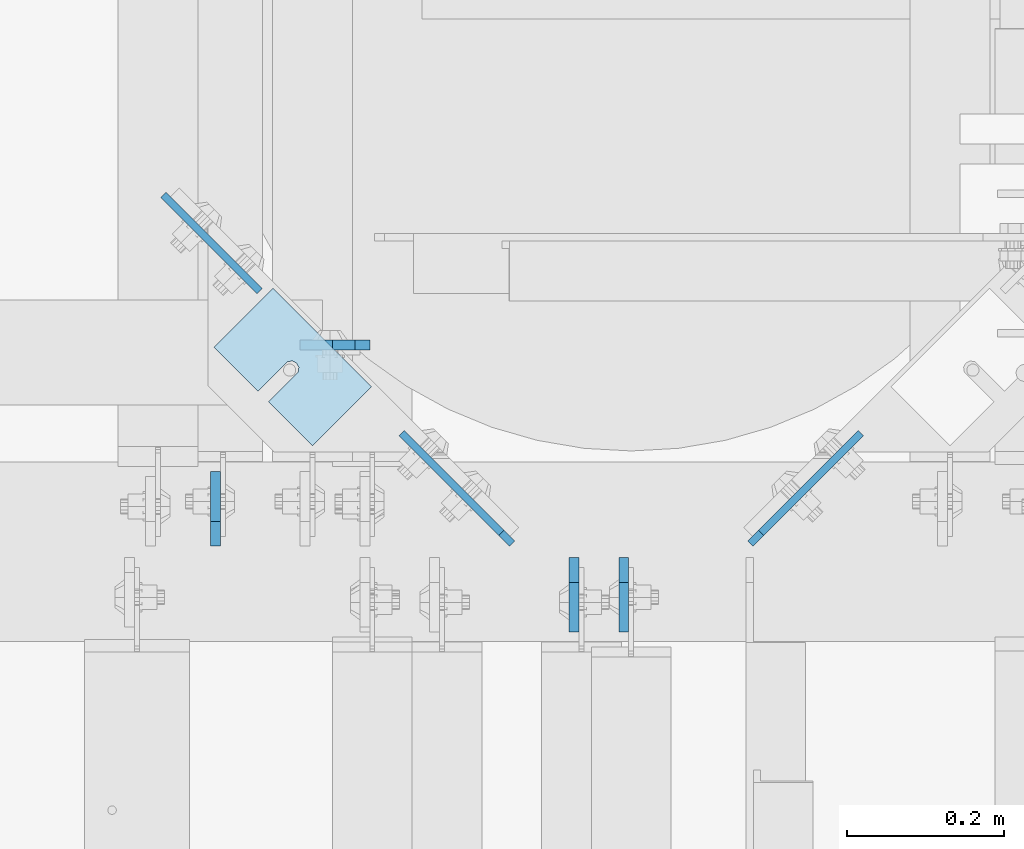
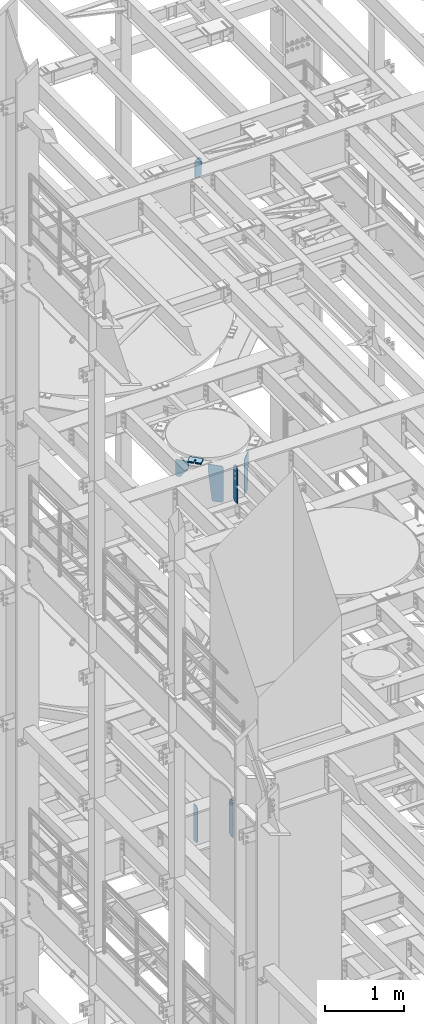
# One storey, part 1702 of 1876: 13 plates, 10 elements without a shape of their own.
"""IFC2X3 building model written with IfcOpenShell, lengths in millimetres."""

from ifc_helpers import new_model, si_unit, frame, origin_with_axes, place, context, subcontext, project, spatial, faceted_brep, material, type_object, element, aggregate, save


model = new_model("IFC2X3")

# Units and contexts
model_context = context("Model", 3, precision=1e-05, world=origin_with_axes())
body_context = subcontext(model_context, "Body", "Model", "MODEL_VIEW")
ifc_project = project(units=[si_unit("LENGTHUNIT", "METRE", prefix="MILLI"), si_unit("AREAUNIT", "SQUARE_METRE"), si_unit("VOLUMEUNIT", "CUBIC_METRE"), si_unit("MASSUNIT", "GRAM", prefix="KILO"), si_unit("TIMEUNIT", "SECOND"), si_unit("PLANEANGLEUNIT", "RADIAN"), si_unit("SOLIDANGLEUNIT", "STERADIAN"), si_unit("THERMODYNAMICTEMPERATUREUNIT", "DEGREE_CELSIUS"), si_unit("LUMINOUSINTENSITYUNIT", "LUMEN")], contexts=[model_context])

# Site, building, storey
site_placement = place(None, origin_with_axes())
site = spatial("IfcSite", under=ifc_project, at=site_placement, CompositionType="ELEMENT")
building_placement = place(site_placement, origin_with_axes())
building = spatial("IfcBuilding", under=site, at=building_placement, Name="Undefined", CompositionType="ELEMENT")
storey_placement = place(building_placement, origin_with_axes())
storey = spatial("IfcBuildingStorey", under=building, at=storey_placement, Name="Undefined", CompositionType="ELEMENT", Elevation=0.0)

# Assembly, plates
assembly_1_placement = place(storey_placement, origin_with_axes())
assembly_1 = element("IfcElementAssembly", 1, at=assembly_1_placement, inside=storey, Name="BEAM", AssemblyPlace="NOTDEFINED", PredefinedType="RIGID_FRAME")
ifc_material = material(Name="STEEL/A36")
plate_type_1 = type_object("IfcPlateType", PredefinedType="NOTDEFINED")
plate_1_placement = place(assembly_1_placement, frame((3339.70512893747, 7630.51134658487, 13275.2197438789), z_axis=(0.707106781186548, 0.707106781186547, 0.0), x_axis=(0.0, 0.0, -1.0)))
plate_1 = element("IfcPlate", 2, at=plate_1_placement, type_object=plate_type_1, material=ifc_material, Name="PLATE", context=body_context, shape_type="Brep", body=[
    faceted_brep([(0.0, -4.76249999999982, 19.0499992370605), (0.0, -4.76250000000027, 198.935516357456), (0.0, 4.76250000000027, 198.935516357456), (0.0, 4.76249999999982, 19.0499992370605), (19.0499992370605, -4.76249999999982, 0.0), (19.0499992370605, 4.76249999999982, 0.0), (543.520313262939, -4.76250000000118, 1.81898940354586e-12), (543.520313262939, 4.76250000000073, 0.0), (562.5703125, -4.76250000000073, 19.0499992370642), (562.5703125, 4.76250000000073, 19.0499992370642), (562.5703125, -4.76250000000027, 148.135517368562), (118.019751450234, -4.76250000000027, 198.935516357456), (118.019751450234, 4.76250000000027, 198.935516357456), (562.5703125, 4.76250000000027, 148.135517368561)], [[[0, 1, 2, 3]], [[4, 0, 3, 5]], [[6, 4, 5, 7]], [[8, 6, 7, 9]], [[1, 0, 4, 6, 8, 10, 11]], [[2, 1, 11, 12]], [[9, 7, 5, 3, 2, 12, 13]], [[8, 9, 13, 10]], [[12, 11, 10, 13]]]),
])
plate_2_placement = place(assembly_1_placement, frame((3035.69487106252, 7630.51134658487, 13275.2197438789), z_axis=(-0.707106781186548, 0.707106781186547, 0.0), x_axis=(0.0, 0.0, -1.0)))
plate_2 = element("IfcPlate", 3, at=plate_2_placement, type_object=plate_type_1, material=ifc_material, Name="PLATE", context=body_context, shape_type="Brep", body=[
    faceted_brep([(0.0, -4.76249999999982, 19.0499992370605), (0.0, -4.76250000000027, 198.935516357456), (0.0, 4.76250000000027, 198.935516357456), (0.0, 4.76249999999982, 19.0499992370605), (19.0499992370605, -4.76249999999982, 0.0), (19.0499992370605, 4.76249999999982, 0.0), (543.520313262939, -4.76250000000118, 1.81898940354586e-12), (543.520313262939, 4.76250000000073, 0.0), (562.5703125, -4.76250000000073, 19.0499992370642), (562.5703125, 4.76250000000073, 19.0499992370642), (562.5703125, -4.76250000000027, 148.135517368562), (118.019751450234, -4.76250000000027, 198.935516357456), (118.019751450234, 4.76250000000027, 198.935516357456), (562.5703125, 4.76250000000027, 148.135517368561)], [[[0, 1, 2, 3]], [[4, 0, 3, 5]], [[6, 4, 5, 7]], [[8, 6, 7, 9]], [[1, 0, 4, 6, 8, 10, 11]], [[2, 1, 11, 12]], [[9, 7, 5, 3, 2, 12, 13]], [[8, 9, 13, 10]], [[12, 11, 10, 13]]]),
])

# Assembly, plate
assembly_2_placement = place(storey_placement, origin_with_axes())
assembly_2 = element("IfcElementAssembly", 4, at=assembly_2_placement, inside=storey, Name="BEAM", AssemblyPlace="NOTDEFINED", PredefinedType="RIGID_FRAME")
plate_type_2 = type_object("IfcPlateType", PredefinedType="NOTDEFINED")
plate_3_placement = place(assembly_2_placement, frame((2590.99259658485, 8075.13584964573, 13271.5), z_axis=(0.707106781186547, -0.707106781186548, 0.0), x_axis=(0.0, 0.0, -1.0)))
plate_3 = element("IfcPlate", 5, at=plate_3_placement, type_object=plate_type_2, material=ifc_material, Name="PLATE", context=body_context, shape_type="Brep", body=[
    faceted_brep([(0.0, -4.76249999999982, 0.0), (0.0, -4.76250000000073, 173.535507202178), (0.0, 4.76250000000073, 173.535507202178), (0.0, 4.76249999999982, 0.0), (241.300006866455, -4.76250000000073, -9.09494701772928e-13), (241.300006866455, 4.76250000000073, 4.54747350886464e-13), (260.350006103516, -4.76250000000073, 19.0499992370633), (260.350006103516, 4.76250000000073, 19.0499992370633), (260.350006103516, -4.76249999999982, 63.4999989557541), (114.299635184505, -4.76250000000073, 173.535507202178), (114.299635184505, 4.76250000000073, 173.535507202178), (260.350006103516, 4.76250000000164, 63.4999989557541)], [[[0, 1, 2, 3]], [[4, 0, 3, 5]], [[6, 4, 5, 7]], [[1, 0, 4, 6, 8, 9]], [[2, 1, 9, 10]], [[7, 5, 3, 2, 10, 11]], [[6, 7, 11, 8]], [[10, 9, 8, 11]]]),
])
aggregate(assembly_2, [plate_3])

assembly_3_placement = place(storey_placement, origin_with_axes())
assembly_3 = element("IfcElementAssembly", 6, at=assembly_3_placement, inside=storey, Name="BEAM", AssemblyPlace="NOTDEFINED", PredefinedType="RIGID_FRAME")
plate_type_3 = type_object("IfcPlateType", PredefinedType="NOTDEFINED")
plate_4_placement = place(assembly_3_placement, frame((2854.325, 7883.6954407692, 17686.3375), z_axis=(0.0, 0.0, 1.0), x_axis=(-1.0, 0.0, 0.0)))
plate_4 = element("IfcPlate", 7, at=plate_4_placement, type_object=plate_type_3, material=ifc_material, Name="PLATE", context=body_context, shape_type="Brep", body=[
    faceted_brep([(0.0, -6.35000000000036, 271.462512969971), (19.0499992370605, -6.35000000000036, 290.512512207031), (19.0499992370605, 6.35000000000036, 290.512512207031), (0.0, 6.35000000000036, 271.462512969971), (0.0, -6.35000000000196, 19.0499992370605), (0.0, 6.35000000000105, 19.0499992370605), (19.0499992370642, -6.35000000000105, 0.0), (19.0499992370633, 6.35000000000105, 0.0), (88.9000015258789, -6.34999999999991, 0.0), (88.9000015258789, 6.34999999999991, 0.0), (88.9000015258789, -6.35000000000036, 249.237510681152), (47.625, -6.35000000000036, 290.512512207031), (47.625, 6.35000000000036, 290.512512207031), (88.9000015258789, 6.35000000000036, 249.237510681152)], [[[0, 1, 2, 3]], [[4, 0, 3, 5]], [[6, 4, 5, 7]], [[8, 6, 7, 9]], [[6, 8, 10, 11, 1, 0, 4]], [[1, 11, 12, 2]], [[2, 12, 13, 9, 7, 5, 3]], [[10, 8, 9, 13]], [[11, 10, 13, 12]]]),
])
aggregate(assembly_3, [plate_4])

# Assembly, plates
assembly_4_placement = place(storey_placement, origin_with_axes())
assembly_4 = element("IfcElementAssembly", 8, at=assembly_4_placement, inside=storey, Name="BEAM", AssemblyPlace="NOTDEFINED", PredefinedType="RIGID_FRAME")
plate_type_4 = type_object("IfcPlateType", PredefinedType="NOTDEFINED")
plate_5_placement = place(assembly_4_placement, frame((3114.67499990463, 7612.85625, 7558.0875), z_axis=(0.0, 0.0, 1.0), x_axis=(0.0, -1.0, 0.0)))
plate_5 = element("IfcPlate", 9, at=plate_5_placement, type_object=plate_type_4, material=ifc_material, Name="PLATE", context=body_context, shape_type="Brep", body=[
    faceted_brep([(0.0, -6.34999999999991, 31.75), (0.0, -6.35000000000036, 538.162475585938), (0.0, 6.35000000000036, 538.162475585938), (0.0, 6.34999999999991, 31.75), (31.75, -6.35000000000036, 569.912475585938), (31.75, 6.35000000000036, 569.912475585938), (95.25, -6.35000000000036, 569.912475585938), (95.25, 6.35000000000036, 569.912475585938), (95.25, -6.35000000000036, 0.0), (95.25, 6.35000000000036, 0.0), (31.75, -6.34999999999991, 0.0), (31.75, 6.34999999999991, 0.0)], [[[0, 1, 2, 3]], [[1, 4, 5, 2]], [[4, 6, 7, 5]], [[6, 8, 9, 7]], [[8, 10, 11, 9]], [[10, 0, 3, 11]], [[5, 7, 9, 11, 3, 2]], [[10, 8, 6, 4, 1, 0]]]),
])
plate_6_placement = place(assembly_4_placement, frame((2657.47499990463, 7627.14375, 7558.0875), z_axis=(0.0, 0.0, 1.0), x_axis=(0.0, 1.0, 0.0)))
plate_6 = element("IfcPlate", 10, at=plate_6_placement, type_object=plate_type_4, material=ifc_material, Name="PLATE", context=body_context, shape_type="Brep", body=[
    faceted_brep([(0.0, -6.34999999999991, 31.75), (0.0, -6.35000000000036, 538.162475585938), (0.0, 6.35000000000036, 538.162475585938), (0.0, 6.34999999999991, 31.75), (31.75, -6.35000000000036, 569.912475585938), (31.75, 6.35000000000036, 569.912475585938), (95.25, -6.35000000000036, 569.912475585938), (95.25, 6.35000000000036, 569.912475585938), (95.25, -6.35000000000036, 0.0), (95.25, 6.35000000000036, 0.0), (31.75, -6.34999999999991, 0.0), (31.75, 6.34999999999991, 0.0)], [[[0, 1, 2, 3]], [[1, 4, 5, 2]], [[4, 6, 7, 5]], [[6, 8, 9, 7]], [[8, 10, 11, 9]], [[10, 0, 3, 11]], [[5, 7, 9, 11, 3, 2]], [[10, 8, 6, 4, 1, 0]]]),
])
aggregate(assembly_4, [plate_5, plate_6])

# Plate
plate_7_placement = place(assembly_1_placement, frame((3178.17499990463, 7612.85625, 12714.2875), z_axis=(0.0, 0.0, 1.0), x_axis=(0.0, -1.0, 0.0)))
plate_7 = element("IfcPlate", 11, at=plate_7_placement, type_object=plate_type_4, material=ifc_material, Name="PLATE", context=body_context, shape_type="Brep", body=[
    faceted_brep([(0.0, -6.34999999999991, 31.75), (0.0, -6.35000000000036, 538.162475585938), (0.0, 6.35000000000036, 538.162475585938), (0.0, 6.34999999999991, 31.75), (31.75, -6.35000000000036, 569.912475585938), (31.75, 6.35000000000036, 569.912475585938), (95.25, -6.35000000000036, 569.912475585938), (95.25, 6.35000000000036, 569.912475585938), (95.25, -6.35000000000036, 0.0), (95.25, 6.35000000000036, 0.0), (31.75, -6.34999999999991, 0.0), (31.75, 6.34999999999991, 0.0)], [[[0, 1, 2, 3]], [[1, 4, 5, 2]], [[4, 6, 7, 5]], [[6, 8, 9, 7]], [[8, 10, 11, 9]], [[10, 0, 3, 11]], [[5, 7, 9, 11, 3, 2]], [[10, 8, 6, 4, 1, 0]]]),
])

aggregate(assembly_1, [plate_1, plate_2, plate_7])

# Assembly, plate
assembly_5_placement = place(storey_placement, origin_with_axes())
assembly_5 = element("IfcElementAssembly", 12, at=assembly_5_placement, inside=storey, Name="SHIM PLATE", AssemblyPlace="NOTDEFINED", PredefinedType="RIGID_FRAME")
plate_type_5 = type_object("IfcPlateType", PredefinedType="NOTDEFINED")
plate_8_placement = place(assembly_5_placement, frame((2856.70239296043, 7830.37621876371, 13335.7925), z_axis=(-0.707118099095974, 0.707095463095965, 0.0), x_axis=(-0.707095463095965, -0.707118099095973, 0.0)))
plate_8 = element("IfcPlate", 13, at=plate_8_placement, type_object=plate_type_5, material=ifc_material, Name="SHIM PLATE", context=body_context, shape_type="Brep", body=[
    faceted_brep([(106.56854125413, -0.793499999999767, 79.3765579294427), (106.56854125413, 0.793499999999767, 79.3765579294427), (58.950614772988, 0.793499999999767, 79.374431191693), (58.950614772988, -0.793499999999767, 79.374431191693), (52.9160762669253, 0.793499999999767, 79.5269726944375), (52.9160762669253, -0.793499999999767, 79.5269726944375), (48.0867887969507, 0.793499999999767, 83.1486996890612), (48.0867887969507, -0.793499999999767, 83.1486996890612), (46.2503144929269, 0.793499999999767, 88.8990288989298), (46.2503144929269, -0.793499999999767, 88.8990288989298), (48.0864248405542, 0.793499999999767, 94.6494743323324), (48.0864248405542, -0.793499999999767, 94.6494743323324), (52.9154830726984, 0.793499999999767, 98.2715069773753), (52.9154830726984, -0.793499999999767, 98.2715069773753), (58.9500119119384, 0.793499999999767, 98.424430420841), (58.9500119119384, -0.793499999999767, 98.424430420841), (106.568229878945, -0.793499999999767, 98.4265571589222), (106.568520818604, 0.793499999999767, 98.4265571592341), (106.568626403816, -0.793499999999767, -2.45563569478691e-11), (9.09494701772928e-13, -0.793499999999767, 0.0), (9.09494701772928e-13, 0.793499999999767, 0.0), (106.568626403816, 0.793499999999767, -2.45563569478691e-11), (-0.0860888362294645, -0.793499999999767, 177.799743652413), (-0.0860888362294645, 0.793499999999767, 177.799743652413), (106.568435668916, -0.793499999999767, 177.803115844783), (106.568435668916, 0.793499999999767, 177.803115844783)], [[[0, 1, 2, 3]], [[3, 2, 4, 5]], [[5, 4, 6, 7]], [[7, 6, 8, 9]], [[9, 8, 10, 11]], [[11, 10, 12, 13]], [[13, 12, 14, 15]], [[16, 15, 14, 17]], [[18, 19, 20, 21]], [[19, 22, 23, 20]], [[22, 24, 25, 23]], [[25, 24, 16, 17]], [[12, 10, 8, 6, 4, 2, 1, 21, 20, 23, 25, 17, 14]], [[18, 21, 1, 0]], [[24, 22, 19, 18, 0, 3, 5, 7, 9, 11, 13, 15, 16]]]),
])
aggregate(assembly_5, [plate_8])

assembly_6_placement = place(storey_placement, origin_with_axes())
assembly_6 = element("IfcElementAssembly", 14, at=assembly_6_placement, inside=storey, Name="SHIM PLATE", AssemblyPlace="NOTDEFINED", PredefinedType="RIGID_FRAME")
plate_type_6 = type_object("IfcPlateType", PredefinedType="NOTDEFINED")
plate_9_placement = place(assembly_6_placement, frame((2856.70239296043, 7830.37621876371, 13333.4115), z_axis=(-0.707118099095974, 0.707095463095965, 0.0), x_axis=(-0.707095463095965, -0.707118099095973, 0.0)))
plate_9 = element("IfcPlate", 15, at=plate_9_placement, type_object=plate_type_6, material=ifc_material, Name="SHIM PLATE", context=body_context, shape_type="Brep", body=[
    faceted_brep([(106.568541254128, -1.58749999999964, 79.3765579294436), (106.568541254128, 1.58749999999964, 79.3765579294436), (58.9506147729862, 1.58749999999964, 79.3744311916935), (58.9506147729862, -1.58749999999964, 79.3744311916935), (52.9160762669235, 1.58749999999964, 79.5269726944384), (52.9160762669235, -1.58749999999964, 79.5269726944384), (48.0867887969489, 1.58749999999964, 83.1486996890617), (48.0867887969489, -1.58749999999964, 83.1486996890617), (46.2503144929269, 1.58749999999964, 88.8990288989303), (46.2503144929269, -1.58749999999964, 88.8990288989303), (48.0864248405524, 1.58749999999964, 94.6494743323319), (48.0864248405524, -1.58749999999964, 94.6494743323319), (52.9154830726966, 1.58749999999964, 98.2715069773753), (52.9154830726966, -1.58749999999964, 98.2715069773753), (58.9500119119384, 1.58749999999964, 98.4244304208414), (58.9500119119384, -1.58749999999964, 98.4244304208414), (106.568229878943, -1.58749999999964, 98.4265571589231), (106.568520818602, 1.58749999999964, 98.426557159235), (106.568626403816, -1.58749999999964, 1.04591890703887e-11), (9.09494701772928e-13, -1.58750000000146, 4.54747350886464e-13), (9.09494701772928e-13, 1.58750000000146, 4.54747350886464e-13), (106.568626403816, 1.58749999999964, 1.04591890703887e-11), (-0.0860888362312835, -1.58749999999964, 177.799743652413), (-0.0860888362312835, 1.58749999999964, 177.799743652413), (106.568435668914, -1.58749999999964, 177.803115844784), (106.568435668914, 1.58749999999964, 177.803115844784)], [[[0, 1, 2, 3]], [[3, 2, 4, 5]], [[5, 4, 6, 7]], [[7, 6, 8, 9]], [[9, 8, 10, 11]], [[11, 10, 12, 13]], [[13, 12, 14, 15]], [[16, 15, 14, 17]], [[18, 19, 20, 21]], [[19, 22, 23, 20]], [[22, 24, 25, 23]], [[25, 24, 16, 17]], [[12, 10, 8, 6, 4, 2, 1, 21, 20, 23, 25, 17, 14]], [[18, 21, 1, 0]], [[24, 22, 19, 18, 0, 3, 5, 7, 9, 11, 13, 15, 16]]]),
])
aggregate(assembly_6, [plate_9])

assembly_7_placement = place(storey_placement, origin_with_axes())
assembly_7 = element("IfcElementAssembly", 16, at=assembly_7_placement, inside=storey, Name="SHIM PLATE", AssemblyPlace="NOTDEFINED", PredefinedType="RIGID_FRAME")
plate_10_placement = place(assembly_7_placement, frame((2856.70239296043, 7830.37621876371, 13330.2365), z_axis=(-0.707118099095974, 0.707095463095965, 0.0), x_axis=(-0.707095463095965, -0.707118099095973, 0.0)))
plate_10 = element("IfcPlate", 17, at=plate_10_placement, type_object=plate_type_6, material=ifc_material, Name="SHIM PLATE", context=body_context, shape_type="Brep", body=[
    faceted_brep([(106.568541254128, -1.58749999999964, 79.3765579294436), (106.568541254128, 1.58749999999964, 79.3765579294436), (58.9506147729862, 1.58749999999964, 79.3744311916935), (58.9506147729862, -1.58749999999964, 79.3744311916935), (52.9160762669235, 1.58749999999964, 79.5269726944384), (52.9160762669235, -1.58749999999964, 79.5269726944384), (48.0867887969489, 1.58749999999964, 83.1486996890617), (48.0867887969489, -1.58749999999964, 83.1486996890617), (46.2503144929269, 1.58749999999964, 88.8990288989303), (46.2503144929269, -1.58749999999964, 88.8990288989303), (48.0864248405524, 1.58749999999964, 94.6494743323319), (48.0864248405524, -1.58749999999964, 94.6494743323319), (52.9154830726966, 1.58749999999964, 98.2715069773753), (52.9154830726966, -1.58749999999964, 98.2715069773753), (58.9500119119384, 1.58749999999964, 98.4244304208414), (58.9500119119384, -1.58749999999964, 98.4244304208414), (106.568229878943, -1.58749999999964, 98.4265571589231), (106.568520818602, 1.58749999999964, 98.426557159235), (106.568626403816, -1.58749999999964, 1.04591890703887e-11), (9.09494701772928e-13, -1.58750000000146, 4.54747350886464e-13), (9.09494701772928e-13, 1.58750000000146, 4.54747350886464e-13), (106.568626403816, 1.58749999999964, 1.04591890703887e-11), (-0.0860888362312835, -1.58749999999964, 177.799743652413), (-0.0860888362312835, 1.58749999999964, 177.799743652413), (106.568435668914, -1.58749999999964, 177.803115844784), (106.568435668914, 1.58749999999964, 177.803115844784)], [[[0, 1, 2, 3]], [[3, 2, 4, 5]], [[5, 4, 6, 7]], [[7, 6, 8, 9]], [[9, 8, 10, 11]], [[11, 10, 12, 13]], [[13, 12, 14, 15]], [[16, 15, 14, 17]], [[18, 19, 20, 21]], [[19, 22, 23, 20]], [[22, 24, 25, 23]], [[25, 24, 16, 17]], [[12, 10, 8, 6, 4, 2, 1, 21, 20, 23, 25, 17, 14]], [[18, 21, 1, 0]], [[24, 22, 19, 18, 0, 3, 5, 7, 9, 11, 13, 15, 16]]]),
])
aggregate(assembly_7, [plate_10])

assembly_8_placement = place(storey_placement, origin_with_axes())
assembly_8 = element("IfcElementAssembly", 18, at=assembly_8_placement, inside=storey, Name="SHIM PLATE", AssemblyPlace="NOTDEFINED", PredefinedType="RIGID_FRAME")
plate_type_7 = type_object("IfcPlateType", PredefinedType="NOTDEFINED")
plate_11_placement = place(assembly_8_placement, frame((2856.70239296043, 7830.37621876371, 13326.268), z_axis=(-0.707118099095974, 0.707095463095965, 0.0), x_axis=(-0.707095463095965, -0.707118099095973, 0.0)))
plate_11 = element("IfcPlate", 19, at=plate_11_placement, type_object=plate_type_7, material=ifc_material, Name="SHIM PLATE", context=body_context, shape_type="Brep", body=[
    faceted_brep([(106.568541254128, -2.3809999999994, 79.3765579294427), (106.568541254128, 2.3809999999994, 79.3765579294427), (58.950614772988, 2.3809999999994, 79.374431191693), (58.950614772988, -2.3809999999994, 79.374431191693), (52.9160762669253, 2.3809999999994, 79.5269726944375), (52.9160762669253, -2.3809999999994, 79.5269726944375), (48.0867887969507, 2.3809999999994, 83.1486996890608), (48.0867887969507, -2.3809999999994, 83.1486996890608), (46.2503144929269, 2.3809999999994, 88.8990288989298), (46.2503144929269, -2.3809999999994, 88.8990288989298), (48.0864248405542, 2.3809999999994, 94.6494743323319), (48.0864248405542, -2.3809999999994, 94.6494743323319), (52.9154830726984, 2.3809999999994, 98.2715069773753), (52.9154830726984, -2.3809999999994, 98.2715069773753), (58.9500119119384, 2.3809999999994, 98.4244304208405), (58.9500119119384, -2.3809999999994, 98.4244304208405), (106.568229878945, -2.3809999999994, 98.4265571589222), (106.568520818604, 2.3809999999994, 98.4265571592341), (106.568626403816, -2.3809999999994, -2.50111042987555e-11), (0.0, -2.38100000000122, 4.54747350886464e-13), (0.0, 2.38100000000122, 4.54747350886464e-13), (106.568626403816, 2.3809999999994, -2.50111042987555e-11), (-0.0860888362312835, -2.3809999999994, 177.799743652412), (-0.0860888362312835, 2.3809999999994, 177.799743652412), (106.568435668916, -2.3809999999994, 177.803115844784), (106.568435668916, 2.3809999999994, 177.803115844784)], [[[0, 1, 2, 3]], [[3, 2, 4, 5]], [[5, 4, 6, 7]], [[7, 6, 8, 9]], [[9, 8, 10, 11]], [[11, 10, 12, 13]], [[13, 12, 14, 15]], [[16, 15, 14, 17]], [[18, 19, 20, 21]], [[19, 22, 23, 20]], [[22, 24, 25, 23]], [[25, 24, 16, 17]], [[12, 10, 8, 6, 4, 2, 1, 21, 20, 23, 25, 17, 14]], [[18, 21, 1, 0]], [[24, 22, 19, 18, 0, 3, 5, 7, 9, 11, 13, 15, 16]]]),
])
aggregate(assembly_8, [plate_11])

assembly_9_placement = place(storey_placement, origin_with_axes())
assembly_9 = element("IfcElementAssembly", 20, at=assembly_9_placement, inside=storey, Name="SHIM PLATE", AssemblyPlace="NOTDEFINED", PredefinedType="RIGID_FRAME")
plate_12_placement = place(assembly_9_placement, frame((2856.70239296043, 7830.37621876371, 13321.506), z_axis=(-0.707118099095974, 0.707095463095965, 0.0), x_axis=(-0.707095463095965, -0.707118099095973, 0.0)))
plate_12 = element("IfcPlate", 21, at=plate_12_placement, type_object=plate_type_7, material=ifc_material, Name="SHIM PLATE", context=body_context, shape_type="Brep", body=[
    faceted_brep([(106.568541254128, -2.3809999999994, 79.3765579294427), (106.568541254128, 2.3809999999994, 79.3765579294427), (58.950614772988, 2.3809999999994, 79.374431191693), (58.950614772988, -2.3809999999994, 79.374431191693), (52.9160762669253, 2.3809999999994, 79.5269726944375), (52.9160762669253, -2.3809999999994, 79.5269726944375), (48.0867887969507, 2.3809999999994, 83.1486996890608), (48.0867887969507, -2.3809999999994, 83.1486996890608), (46.2503144929269, 2.3809999999994, 88.8990288989298), (46.2503144929269, -2.3809999999994, 88.8990288989298), (48.0864248405542, 2.3809999999994, 94.6494743323319), (48.0864248405542, -2.3809999999994, 94.6494743323319), (52.9154830726984, 2.3809999999994, 98.2715069773753), (52.9154830726984, -2.3809999999994, 98.2715069773753), (58.9500119119384, 2.3809999999994, 98.4244304208405), (58.9500119119384, -2.3809999999994, 98.4244304208405), (106.568229878945, -2.3809999999994, 98.4265571589222), (106.568520818604, 2.3809999999994, 98.4265571592341), (106.568626403816, -2.3809999999994, -2.50111042987555e-11), (0.0, -2.38100000000122, 4.54747350886464e-13), (0.0, 2.38100000000122, 4.54747350886464e-13), (106.568626403816, 2.3809999999994, -2.50111042987555e-11), (-0.0860888362312835, -2.3809999999994, 177.799743652412), (-0.0860888362312835, 2.3809999999994, 177.799743652412), (106.568435668916, -2.3809999999994, 177.803115844784), (106.568435668916, 2.3809999999994, 177.803115844784)], [[[0, 1, 2, 3]], [[3, 2, 4, 5]], [[5, 4, 6, 7]], [[7, 6, 8, 9]], [[9, 8, 10, 11]], [[11, 10, 12, 13]], [[13, 12, 14, 15]], [[16, 15, 14, 17]], [[18, 19, 20, 21]], [[19, 22, 23, 20]], [[22, 24, 25, 23]], [[25, 24, 16, 17]], [[12, 10, 8, 6, 4, 2, 1, 21, 20, 23, 25, 17, 14]], [[18, 21, 1, 0]], [[24, 22, 19, 18, 0, 3, 5, 7, 9, 11, 13, 15, 16]]]),
])
aggregate(assembly_9, [plate_12])

assembly_10_placement = place(storey_placement, origin_with_axes())
assembly_10 = element("IfcElementAssembly", 22, at=assembly_10_placement, inside=storey, Name="SHIM PLATE", AssemblyPlace="NOTDEFINED", PredefinedType="RIGID_FRAME")
plate_type_8 = type_object("IfcPlateType", PredefinedType="NOTDEFINED")
plate_13_placement = place(assembly_10_placement, frame((2856.70239296043, 7830.37621876371, 13314.3625), z_axis=(-0.707118099095974, 0.707095463095965, 0.0), x_axis=(-0.707095463095965, -0.707118099095973, 0.0)))
plate_13 = element("IfcPlate", 23, at=plate_13_placement, type_object=plate_type_8, material=ifc_material, Name="SHIM PLATE", context=body_context, shape_type="Brep", body=[
    faceted_brep([(106.568541254128, -4.76250000000073, 79.3765579294432), (106.568541254128, 4.76250000000073, 79.3765579294432), (58.950614772988, 4.76250000000073, 79.3744311916935), (58.950614772988, -4.76250000000073, 79.3744311916935), (52.9160762669235, 4.76250000000073, 79.5269726944393), (52.9160762669235, -4.76250000000073, 79.5269726944393), (48.0867887969489, 4.76250000000073, 83.1486996890617), (48.0867887969489, -4.76250000000073, 83.1486996890617), (46.2503144929269, 4.76250000000073, 88.8990288989303), (46.2503144929269, -4.76250000000073, 88.8990288989303), (48.0864248405524, 4.76250000000073, 94.6494743323324), (48.0864248405524, -4.76250000000073, 94.6494743323324), (52.9154830726966, 4.76250000000073, 98.2715069773762), (52.9154830726966, -4.76250000000073, 98.2715069773762), (58.9500119119384, 4.76250000000073, 98.4244304208414), (58.9500119119384, -4.76250000000073, 98.4244304208414), (106.568229878945, -4.76250000000073, 98.4265571589226), (106.568520818604, 4.76250000000073, 98.426557159235), (106.568626403816, -4.76250000000073, 9.54969436861575e-12), (0.0, -4.76249999999982, 0.0), (0.0, 4.76249999999982, 0.0), (106.568626403816, 4.76250000000073, 9.54969436861575e-12), (-0.0860888362312835, -4.76250000000073, 177.799743652414), (-0.0860888362312835, 4.76250000000073, 177.799743652414), (106.568435668916, -4.76250000000073, 177.803115844784), (106.568435668916, 4.76250000000073, 177.803115844784)], [[[0, 1, 2, 3]], [[3, 2, 4, 5]], [[5, 4, 6, 7]], [[7, 6, 8, 9]], [[9, 8, 10, 11]], [[11, 10, 12, 13]], [[13, 12, 14, 15]], [[16, 15, 14, 17]], [[18, 19, 20, 21]], [[19, 22, 23, 20]], [[22, 24, 25, 23]], [[25, 24, 16, 17]], [[12, 10, 8, 6, 4, 2, 1, 21, 20, 23, 25, 17, 14]], [[18, 21, 1, 0]], [[24, 22, 19, 18, 0, 3, 5, 7, 9, 11, 13, 15, 16]]]),
])
aggregate(assembly_10, [plate_13])

save(model, "model.ifc")
